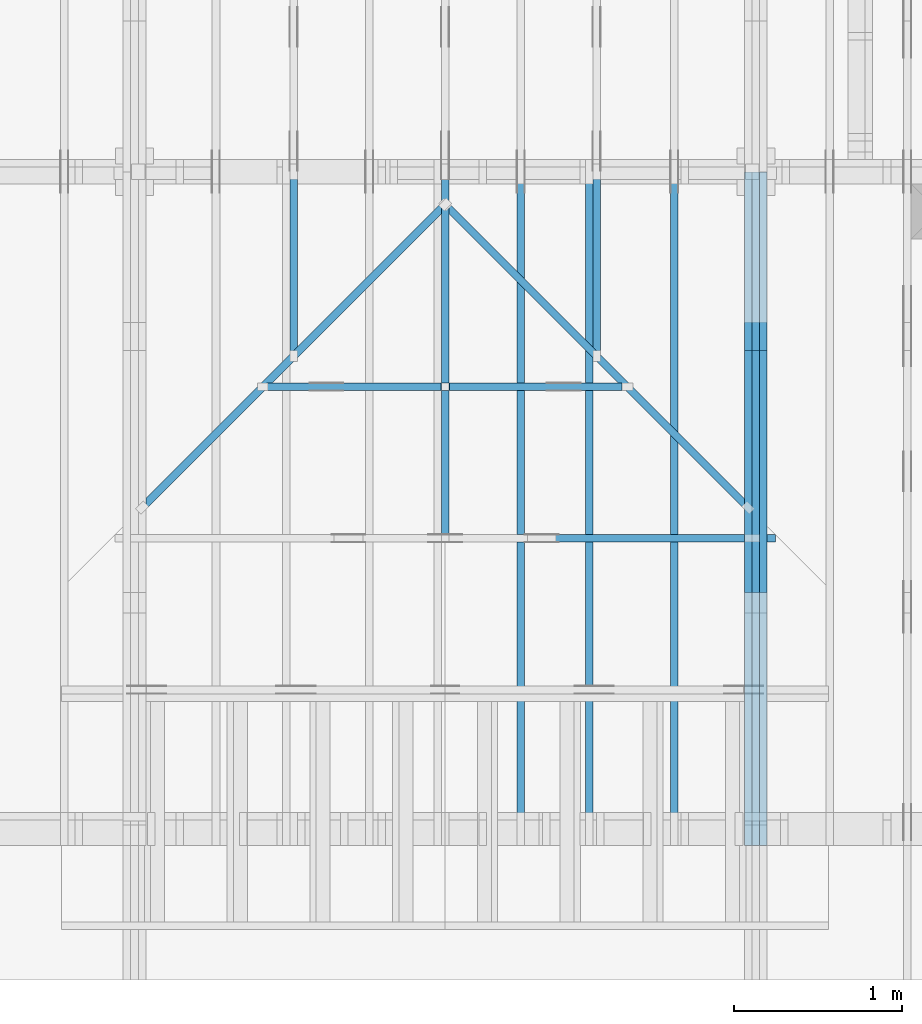
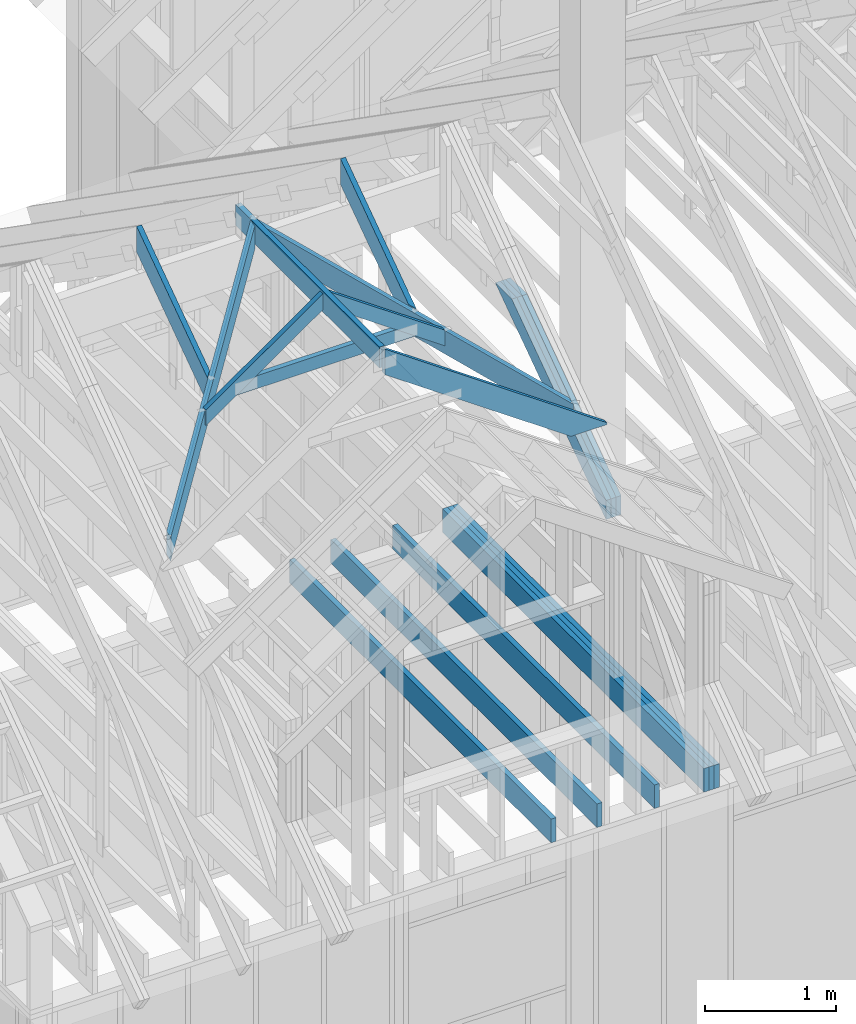
# One storey, part 9 of 70: 18 members, 11 elements without a shape of their own.
"""IFC2X3 building model written with IfcOpenShell, lengths in millimetres."""

from ifc_helpers import new_model, si_unit, frame, origin, origin_with_axes, origin_2d, place, context, project, spatial, faceted_brep, element, aggregate, save


model = new_model("IFC2X3")

# Units and contexts
model_context = context("Model", 3, precision=1e-05, world=origin())
plan_context = context("Plan", 2, precision=1e-05, world=origin_2d())
ifc_project = project(units=[si_unit("LENGTHUNIT", "METRE", prefix="MILLI"), si_unit("AREAUNIT", "SQUARE_METRE"), si_unit("VOLUMEUNIT", "CUBIC_METRE"), si_unit("SOLIDANGLEUNIT", "STERADIAN"), si_unit("PLANEANGLEUNIT", "RADIAN"), si_unit("MASSUNIT", "GRAM"), si_unit("TIMEUNIT", "SECOND"), si_unit("THERMODYNAMICTEMPERATUREUNIT", "DEGREE_CELSIUS"), si_unit("LUMINOUSINTENSITYUNIT", "LUMEN")], contexts=[model_context, plan_context])

# Site, building, storey
site_placement = place(None, origin_with_axes())
site = spatial("IfcSite", under=ifc_project, at=site_placement, CompositionType="ELEMENT")
building_placement = place(site_placement, origin_with_axes())
building = spatial("IfcBuilding", under=site, at=building_placement, Name="Layout 1", CompositionType="ELEMENT")
storey_placement = place(building_placement, origin_with_axes())
storey = spatial("IfcBuildingStorey", under=building, at=storey_placement, Name="Storey 1", CompositionType="ELEMENT", Elevation=0.0)

# Assembly, members
assembly_1_placement = place(storey_placement, frame((5660.000000000293, 8000.0, 9.122500660690286e-13), z_axis=(-1.0, 1.836909530733566e-16, 6.123031769111886e-17), x_axis=(-1.836909530733566e-16, -1.0, 0.0)))
assembly_1 = element("IfcElementAssembly", 1, at=assembly_1_placement, inside=storey, Name="T11", AssemblyPlace="FACTORY", PredefinedType="TRUSS")
member_1_placement = place(assembly_1_placement, frame((7999.999999999999, 220.0, -90.0), z_axis=(0.0, 0.0, 1.0), x_axis=(-1.0, 1.2246063538223773e-16, 0.0)))
member_1 = element("IfcMember", 2, at=member_1_placement, Name="B3", context=model_context, shape_type="Brep", body=[
    faceted_brep([(3999.9999999999995, 220.00000000000054, 45.0), (0.0, 220.00000000000054, 45.0), (0.0, 0.0, 45.0), (3999.9999999999995, 0.0, 45.0), (0.0, 220.00000000000054, 0.0), (3999.9999999999995, 220.00000000000054, 4.898425415289508e-13), (3999.9999999999995, 0.0, 4.898425415289508e-13), (0.0, 0.0, 0.0), (0.0, 0.0, 0.0), (2.755364296100349e-15, -3.3742366240998092e-31, 45.0), (2.969670408019265e-14, 220.0, 45.0), (2.69413397840923e-14, 220.0, -1.6496267940043512e-30), (3999.9999999999995, -7.347638122934263e-13, 7.805495731188194e-29), (3999.9999999999995, -7.320084479973259e-13, 45.0), (5.061354936149714e-31, 2.755364296100349e-15, 45.0), (0.0, 0.0, 0.0), (3999.9999999999995, 220.00000000000054, 0.0), (3999.9999999999995, 220.00000000000054, 45.0), (3999.9999999999995, 5.400124791776761e-13, 45.0), (3999.9999999999995, 5.400124791776761e-13, 0.0), (0.0, 220.0, 0.0), (0.0, 220.0, 45.0), (3999.9999999999995, 220.00000000000065, 45.0), (3999.9999999999995, 220.00000000000065, 6.310887241768095e-30)], [[[0, 1, 2, 3]], [[4, 5, 6, 7]], [[8, 9, 10, 11]], [[12, 13, 14, 15]], [[16, 17, 18, 19]], [[20, 21, 22, 23]]]),
])
member_2_placement = place(assembly_1_placement, frame((7999.999999999999, 220.0, -135.0), z_axis=(0.0, 0.0, 1.0), x_axis=(-1.0, 1.2246063538223773e-16, 0.0)))
member_2 = element("IfcMember", 3, at=member_2_placement, Name="B3", context=model_context, shape_type="Brep", body=[
    faceted_brep([(3999.9999999999995, 220.00000000000054, 45.0), (0.0, 220.00000000000054, 45.0), (0.0, 0.0, 45.0), (3999.9999999999995, 0.0, 45.0), (0.0, 220.00000000000054, 0.0), (3999.9999999999995, 220.00000000000054, 4.898425415289508e-13), (3999.9999999999995, 0.0, 4.898425415289508e-13), (0.0, 0.0, 0.0), (0.0, 0.0, 0.0), (2.755364296100349e-15, -3.3742366240998092e-31, 45.0), (2.969670408019265e-14, 220.0, 45.0), (2.69413397840923e-14, 220.0, -1.6496267940043512e-30), (3999.9999999999995, -7.347638122934263e-13, 7.805495731188194e-29), (3999.9999999999995, -7.320084479973259e-13, 45.0), (5.061354936149714e-31, 2.755364296100349e-15, 45.0), (0.0, 0.0, 0.0), (3999.9999999999995, 220.00000000000054, 0.0), (3999.9999999999995, 220.00000000000054, 45.0), (3999.9999999999995, 5.400124791776761e-13, 45.0), (3999.9999999999995, 5.400124791776761e-13, 0.0), (0.0, 220.0, 0.0), (0.0, 220.0, 45.0), (3999.9999999999995, 220.00000000000065, 45.0), (3999.9999999999995, 220.00000000000065, 6.310887241768095e-30)], [[[0, 1, 2, 3]], [[4, 5, 6, 7]], [[8, 9, 10, 11]], [[12, 13, 14, 15]], [[16, 17, 18, 19]], [[20, 21, 22, 23]]]),
])
member_3_placement = place(assembly_1_placement, frame((7999.999999999999, 220.0, -180.0), z_axis=(0.0, 0.0, 1.0), x_axis=(-1.0, 1.2246063538223773e-16, 0.0)))
member_3 = element("IfcMember", 4, at=member_3_placement, Name="B3", context=model_context, shape_type="Brep", body=[
    faceted_brep([(3999.9999999999995, 220.00000000000054, 45.0), (0.0, 220.00000000000054, 45.0), (0.0, 0.0, 45.0), (3999.9999999999995, 0.0, 45.0), (0.0, 220.00000000000054, 0.0), (3999.9999999999995, 220.00000000000054, 4.898425415289508e-13), (3999.9999999999995, 0.0, 4.898425415289508e-13), (0.0, 0.0, 0.0), (0.0, 0.0, 0.0), (2.755364296100349e-15, -3.3742366240998092e-31, 45.0), (2.969670408019265e-14, 220.0, 45.0), (2.69413397840923e-14, 220.0, -1.6496267940043512e-30), (3999.9999999999995, -7.347638122934263e-13, 7.805495731188194e-29), (3999.9999999999995, -7.320084479973259e-13, 45.0), (5.061354936149714e-31, 2.755364296100349e-15, 45.0), (0.0, 0.0, 0.0), (3999.9999999999995, 220.00000000000054, 0.0), (3999.9999999999995, 220.00000000000054, 45.0), (3999.9999999999995, 5.400124791776761e-13, 45.0), (3999.9999999999995, 5.400124791776761e-13, 0.0), (0.0, 220.0, 0.0), (0.0, 220.0, 45.0), (3999.9999999999995, 220.00000000000065, 45.0), (3999.9999999999995, 220.00000000000065, 6.310887241768095e-30)], [[[0, 1, 2, 3]], [[4, 5, 6, 7]], [[8, 9, 10, 11]], [[12, 13, 14, 15]], [[16, 17, 18, 19]], [[20, 21, 22, 23]]]),
])
member_4_placement = place(assembly_1_placement, frame((6583.168583266467, 1754.0249935609681, -90.0), z_axis=(0.0, 0.0, 1.0), x_axis=(-0.8191520442887741, 0.573576436351357, 0.0)))
member_4 = element("IfcMember", 5, at=member_4_placement, Name="SC5", context=model_context, shape_type="Brep", body=[
    faceted_brep([(2065.5521701629054, 145.00000000003, 45.0), (0.0, 145.00000000003, 45.0), (101.53009304118586, 0.0, 45.0), (1858.4707091852106, 0.0, 45.0), (0.0, 145.00000000003, 0.0), (2065.5521701629054, 145.00000000003, 2.529488311733094e-13), (1858.4707091852106, 0.0, 2.275895038860988e-13), (101.53009304118586, 0.0, 1.2433439704241334e-14), (101.53009304118586, 0.0, 4.2995835069684415e-31), (101.53009304118586, 0.0, 45.0), (2.842170943040401e-14, 145.0000000000155, 45.0), (2.842170943040401e-14, 145.0000000000155, -2.4234235555743734e-30), (1858.4707091852106, 2.77410857254784e-11, 2.7752643298715197e-29), (1858.4707091852106, 2.77438410897745e-11, 45.0), (101.53009304118586, -2.2006133120472472e-14, 45.0), (101.53009304118586, -2.476149741657282e-14, 1.5161543533245607e-30), (2065.5521701629054, 145.0000000000299, 1.0940328964451725e-29), (2065.5521701629054, 145.0000000000299, 45.0), (1858.4707091852106, 2.808064891723916e-11, 45.0), (1858.4707091852106, 2.808064891723916e-11, 9.382329999429724e-30), (0.0, 145.00000000001546, 0.0), (0.0, 145.00000000001546, 45.0), (2065.5521701629054, 145.00000000003047, 45.0), (2065.5521701629054, 145.00000000003047, 2.68212707775144e-29)], [[[0, 1, 2, 3]], [[4, 5, 6, 7]], [[8, 9, 10, 11]], [[12, 13, 14, 15]], [[16, 17, 18, 19]], [[20, 21, 22, 23]]]),
])
member_5_placement = place(assembly_1_placement, frame((6583.168583266467, 1754.0249935609681, -135.0), z_axis=(0.0, 0.0, 1.0), x_axis=(-0.8191520442887741, 0.573576436351357, 0.0)))
member_5 = element("IfcMember", 6, at=member_5_placement, Name="SC5", context=model_context, shape_type="Brep", body=[
    faceted_brep([(2065.5521701629054, 145.00000000003, 45.0), (0.0, 145.00000000003, 45.0), (101.53009304118586, 0.0, 45.0), (1858.4707091852106, 0.0, 45.0), (0.0, 145.00000000003, 0.0), (2065.5521701629054, 145.00000000003, 2.529488311733094e-13), (1858.4707091852106, 0.0, 2.275895038860988e-13), (101.53009304118586, 0.0, 1.2433439704241334e-14), (101.53009304118586, 0.0, 4.2995835069684415e-31), (101.53009304118586, 0.0, 45.0), (2.842170943040401e-14, 145.0000000000155, 45.0), (2.842170943040401e-14, 145.0000000000155, -2.4234235555743734e-30), (1858.4707091852106, 2.77410857254784e-11, 2.7752643298715197e-29), (1858.4707091852106, 2.77438410897745e-11, 45.0), (101.53009304118586, -2.2006133120472472e-14, 45.0), (101.53009304118586, -2.476149741657282e-14, 1.5161543533245607e-30), (2065.5521701629054, 145.0000000000299, 1.0940328964451725e-29), (2065.5521701629054, 145.0000000000299, 45.0), (1858.4707091852106, 2.808064891723916e-11, 45.0), (1858.4707091852106, 2.808064891723916e-11, 9.382329999429724e-30), (0.0, 145.00000000001546, 0.0), (0.0, 145.00000000001546, 45.0), (2065.5521701629054, 145.00000000003047, 45.0), (2065.5521701629054, 145.00000000003047, 2.68212707775144e-29)], [[[0, 1, 2, 3]], [[4, 5, 6, 7]], [[8, 9, 10, 11]], [[12, 13, 14, 15]], [[16, 17, 18, 19]], [[20, 21, 22, 23]]]),
])
member_6_placement = place(assembly_1_placement, frame((6583.168583266467, 1754.0249935609681, -180.0), z_axis=(0.0, 0.0, 1.0), x_axis=(-0.8191520442887741, 0.573576436351357, 0.0)))
member_6 = element("IfcMember", 7, at=member_6_placement, Name="SC5", context=model_context, shape_type="Brep", body=[
    faceted_brep([(2065.5521701629054, 145.00000000003, 45.0), (0.0, 145.00000000003, 45.0), (101.53009304118586, 0.0, 45.0), (1858.4707091852106, 0.0, 45.0), (0.0, 145.00000000003, 0.0), (2065.5521701629054, 145.00000000003, 2.529488311733094e-13), (1858.4707091852106, 0.0, 2.275895038860988e-13), (101.53009304118586, 0.0, 1.2433439704241334e-14), (101.53009304118586, 0.0, 4.2995835069684415e-31), (101.53009304118586, 0.0, 45.0), (2.842170943040401e-14, 145.0000000000155, 45.0), (2.842170943040401e-14, 145.0000000000155, -2.4234235555743734e-30), (1858.4707091852106, 2.77410857254784e-11, 2.7752643298715197e-29), (1858.4707091852106, 2.77438410897745e-11, 45.0), (101.53009304118586, -2.2006133120472472e-14, 45.0), (101.53009304118586, -2.476149741657282e-14, 1.5161543533245607e-30), (2065.5521701629054, 145.0000000000299, 1.0940328964451725e-29), (2065.5521701629054, 145.0000000000299, 45.0), (1858.4707091852106, 2.808064891723916e-11, 45.0), (1858.4707091852106, 2.808064891723916e-11, 9.382329999429724e-30), (0.0, 145.00000000001546, 0.0), (0.0, 145.00000000001546, 45.0), (2065.5521701629054, 145.00000000003047, 45.0), (2065.5521701629054, 145.00000000003047, 2.68212707775144e-29)], [[[0, 1, 2, 3]], [[4, 5, 6, 7]], [[8, 9, 10, 11]], [[12, 13, 14, 15]], [[16, 17, 18, 19]], [[20, 21, 22, 23]]]),
])
aggregate(assembly_1, [member_1, member_2, member_3, member_4, member_5, member_6])

# Assembly, member
assembly_2_placement = place(storey_placement, frame((4355.0, 8000.0, 1.3776821480501744e-15), z_axis=(-1.0, 1.836909530733566e-16, 6.123031769111886e-17), x_axis=(-1.836909530733566e-16, -1.0, 0.0)))
assembly_2 = element("IfcElementAssembly", 8, at=assembly_2_placement, inside=storey, Name="MB1", AssemblyPlace="FACTORY", PredefinedType="TRUSS")
member_7_placement = place(assembly_2_placement, frame((8000.000000000001, 220.0, -45.0), z_axis=(0.0, 0.0, 1.0), x_axis=(-1.0, 1.2246063538223773e-16, 0.0)))
member_7 = element("IfcMember", 9, at=member_7_placement, Name="B3", context=model_context, shape_type="Brep", body=[
    faceted_brep([(4000.0000000000005, 220.0000000000005, 45.0), (0.0, 220.0000000000005, 45.0), (0.0, 0.0, 45.0), (4000.0000000000005, 0.0, 45.0), (0.0, 220.0000000000005, 0.0), (4000.0000000000005, 220.0000000000005, 4.89842541528951e-13), (4000.0000000000005, 0.0, 4.89842541528951e-13), (0.0, 0.0, 0.0), (0.0, 0.0, 0.0), (2.755364296100349e-15, -3.3742366240998092e-31, 45.0), (2.969670408019265e-14, 220.0, 45.0), (2.69413397840923e-14, 220.0, -1.6496267940043512e-30), (4000.0000000000005, -7.347638122934265e-13, 7.631468701413364e-29), (4000.0000000000005, -7.320084479973261e-13, 45.0), (5.061354936149714e-31, 2.755364296100349e-15, 45.0), (0.0, 0.0, 0.0), (4000.0000000000005, 220.0000000000005, 0.0), (4000.0000000000005, 220.0000000000005, 45.0), (4000.0000000000005, 5.115907697472721e-13, 45.0), (4000.0000000000005, 5.115907697472721e-13, 0.0), (0.0, 220.0, 0.0), (0.0, 220.0, 45.0), (4000.0000000000005, 220.00000000000065, 45.0), (4000.0000000000005, 220.00000000000065, 7.888609052210118e-30)], [[[0, 1, 2, 3]], [[4, 5, 6, 7]], [[8, 9, 10, 11]], [[12, 13, 14, 15]], [[16, 17, 18, 19]], [[20, 21, 22, 23]]]),
])
aggregate(assembly_2, [member_7])

assembly_3_placement = place(storey_placement, frame((5266.250000000146, 8000.0, 1.3776821480501744e-15), z_axis=(-1.0, 1.836909530733566e-16, 6.123031769111886e-17), x_axis=(-1.836909530733566e-16, -1.0, 0.0)))
assembly_3 = element("IfcElementAssembly", 10, at=assembly_3_placement, inside=storey, Name="MB1", AssemblyPlace="FACTORY", PredefinedType="TRUSS")
member_8_placement = place(assembly_3_placement, frame((8000.000000000001, 220.0, -45.0), z_axis=(0.0, 0.0, 1.0), x_axis=(-1.0, 1.2246063538223773e-16, 0.0)))
member_8 = element("IfcMember", 11, at=member_8_placement, Name="B3", context=model_context, shape_type="Brep", body=[
    faceted_brep([(4000.0000000000005, 220.0000000000005, 45.0), (0.0, 220.0000000000005, 45.0), (0.0, 0.0, 45.0), (4000.0000000000005, 0.0, 45.0), (0.0, 220.0000000000005, 0.0), (4000.0000000000005, 220.0000000000005, 4.89842541528951e-13), (4000.0000000000005, 0.0, 4.89842541528951e-13), (0.0, 0.0, 0.0), (0.0, 0.0, 0.0), (2.755364296100349e-15, -3.3742366240998092e-31, 45.0), (2.969670408019265e-14, 220.0, 45.0), (2.69413397840923e-14, 220.0, -1.6496267940043512e-30), (4000.0000000000005, -7.347638122934265e-13, 7.631468701413364e-29), (4000.0000000000005, -7.320084479973261e-13, 45.0), (5.061354936149714e-31, 2.755364296100349e-15, 45.0), (0.0, 0.0, 0.0), (4000.0000000000005, 220.0000000000005, 0.0), (4000.0000000000005, 220.0000000000005, 45.0), (4000.0000000000005, 5.115907697472721e-13, 45.0), (4000.0000000000005, 5.115907697472721e-13, 0.0), (0.0, 220.0, 0.0), (0.0, 220.0, 45.0), (4000.0000000000005, 220.00000000000065, 45.0), (4000.0000000000005, 220.00000000000065, 7.888609052210118e-30)], [[[0, 1, 2, 3]], [[4, 5, 6, 7]], [[8, 9, 10, 11]], [[12, 13, 14, 15]], [[16, 17, 18, 19]], [[20, 21, 22, 23]]]),
])
aggregate(assembly_3, [member_8])

assembly_4_placement = place(storey_placement, frame((5910.470169573801, 1845.0, 1.3776821480501744e-15), z_axis=(1.2246063538223773e-16, 1.0, 6.123031769111886e-17), x_axis=(-1.0, 1.2246063538223773e-16, 0.0)))
assembly_4 = element("IfcElementAssembly", 12, at=assembly_4_placement, inside=storey, Name="T6", AssemblyPlace="FACTORY", PredefinedType="TRUSS")
member_9_placement = place(assembly_4_placement, frame((126.94513170141886, 2126.9651317341068, -45.0), z_axis=(0.0, 0.0, 1.0), x_axis=(0.8191520442889915, 0.5735764363510465, 0.0)))
member_9 = element("IfcMember", 13, at=member_9_placement, Name="T15", context=model_context, shape_type="Brep", body=[
    faceted_brep([(2402.328672292534, 195.0000000028765, 45.0), (9.036507251027615, 195.0000000028765, 45.0), (0.0, 182.09453018306226, 45.0), (260.05794032032895, 0.0, 45.0), (2265.788202340448, 0.0, 45.0), (9.036507251027615, 195.0000000028765, 1.10661641959704e-15), (2402.328672292534, 195.0000000028765, 2.9419069560591125e-13), (2265.788202340448, 0.0, 2.774698629001895e-13), (260.05794032032895, 0.0, 3.1846860607823545e-14), (0.0, 182.09453018306226, 0.0), (0.0, 182.09453018306226, 1.70814952506554e-30), (0.0, 182.09453018306226, 45.0), (9.03650725102763, 195.00000000152798, 45.0), (9.03650725102763, 195.00000000152798, 1.8052451729587168e-30), (260.0579403203289, -4.263256414560601e-14, 4.733165431326071e-30), (260.0579403203289, -4.263256414560601e-14, 45.0), (4.263256414560601e-14, 182.09453018306232, 45.0), (4.263256414560601e-14, 182.09453018306232, -4.733165431326071e-30), (2265.788202340448, 1.1716974645044216e-09, 6.710557680191079e-29), (2265.788202340448, 1.1717002198687177e-09, 45.0), (260.05794032032895, -1.2303370630569984e-13, 45.0), (260.05794032032895, -1.257890706018002e-13, 7.702104755019455e-30), (2402.3286722925336, 195.0000000028772, -3.7865323450608567e-29), (2402.3286722925336, 195.0000000028772, 45.0), (2265.7882023404477, 1.1732481652870774e-09, 45.0), (2265.7882023404477, 1.1732481652870774e-09, -3.7865323450608567e-29), (9.036507251027615, 195.00000000152795, 0.0), (9.036507251027615, 195.00000000152795, 45.0), (2402.328672292534, 195.00000000287653, 45.0), (2402.328672292534, 195.00000000287653, 3.1554436208840472e-30)], [[[0, 1, 2, 3, 4]], [[5, 6, 7, 8, 9]], [[10, 11, 12, 13]], [[14, 15, 16, 17]], [[18, 19, 20, 21]], [[22, 23, 24, 25]], [[26, 27, 28, 29]]]),
])
aggregate(assembly_4, [member_9])

# Assembly, members
assembly_5_placement = place(storey_placement, frame((5010.470169573802, 2745.0, 1.3776821480501744e-15), z_axis=(1.2246063538223773e-16, 1.0, 6.123031769111886e-17), x_axis=(-1.0, 1.2246063538223773e-16, 0.0)))
assembly_5 = element("IfcElementAssembly", 14, at=assembly_5_placement, inside=storey, Name="T5", AssemblyPlace="FACTORY", PredefinedType="TRUSS")
member_10_placement = place(assembly_5_placement, frame((31.8198051533941, 2782.102539556101, -45.0), z_axis=(0.0, 0.0, 1.0), x_axis=(0.8191520442889916, 0.5735764363510464, 0.0)))
member_10 = element("IfcMember", 15, at=member_10_placement, Name="T23", context=model_context, shape_type="Brep", body=[
    faceted_brep([(1336.1128064243578, 120.00000000153977, 45.0), (84.02490458540615, 120.00000000153977, 45.0), (0.0, 2.684828359633684e-09, 45.0), (1252.0879018399944, 2.684828359633684e-09, 45.0), (84.02490458540615, 120.00000000034379, 1.0289743203460738e-14), (1336.1128064243578, 120.00000000034379, 1.6362122321707165e-13), (1252.0879018399944, 2.684828359633684e-09, 1.5333148001373862e-13), (0.0, 2.684828359633684e-09, 0.0), (84.02490458540615, 120.00000000034379, 0.0), (84.02490458540615, 120.00000000034377, 45.0), (1336.1128064243578, 120.00000000153975, 45.0), (1336.1128064243578, 120.00000000153975, -3.1554436208840472e-30), (1.164085069105157e-14, -8.151011405048039e-15, -8.701351488741532e-31), (1.3897912986963067e-14, -9.731423438854188e-15, 45.0), (84.02490458540613, 120.00000000034379, 45.0), (84.02490458540613, 120.00000000034379, 2.399280079755067e-30), (1252.0879018399944, 2.684324976692266e-09, 3.08222974233199e-29), (1252.0879018399944, 2.684327732056562e-09, 45.0), (-5.9071676908938386e-27, 2.755364296100349e-15, 45.0), (0.0, 0.0, 0.0), (1336.1128064243585, 120.00000000153955, 3.7865323450608567e-29), (1336.1128064243585, 120.00000000153955, 45.0), (1252.0879018399949, 2.6844872991205193e-09, 45.0), (1252.0879018399949, 2.6844872991205193e-09, 3.7865323450608567e-29)], [[[0, 1, 2, 3]], [[4, 5, 6, 7]], [[8, 9, 10, 11]], [[12, 13, 14, 15]], [[16, 17, 18, 19]], [[20, 21, 22, 23]]]),
])
member_11_placement = place(assembly_5_placement, frame((1039.6409972112772, 3548.465361629326, -45.00000000000001), z_axis=(0.0, 0.0, 1.0), x_axis=(0.8191520442889916, -0.5735764363510465, 0.0)))
member_11 = element("IfcMember", 16, at=member_11_placement, Name="T22", context=model_context, shape_type="Brep", body=[
    faceted_brep([(1263.465283141054, 120.00000000181171, 45.0), (0.0, 120.00000000181171, 45.0), (84.02490458540615, 0.0, 45.0), (1347.49018772646, 0.0, 45.0), (0.0, 120.00000000181171, 0.0), (1263.465283141054, 120.00000000181171, 1.5472476135685237e-13), (1347.49018772646, 0.0, 1.6501450456031308e-13), (84.02490458540615, 0.0, 1.0289743203460738e-14), (84.02490458540615, -2.1316282072803006e-14, 7.888609052210116e-31), (84.02490458540615, -2.1316282072803006e-14, 45.0), (4.263256414560601e-14, 120.00000000034382, 45.0), (4.263256414560601e-14, 120.00000000034382, -3.1554436208840472e-30), (1347.49018772646, 1.4675600276772321e-09, 2.2313612640413609e-29), (1347.49018772646, 1.4675627830415282e-09, 45.0), (84.02490458540615, -1.9968688696242525e-14, 45.0), (84.02490458540615, -2.2724052992342873e-14, 1.3914009839511772e-30), (1263.4652831410542, 120.00000000181171, 1.262177448353619e-29), (1263.4652831410542, 120.00000000181171, 45.0), (1347.4901877264601, 1.4680381354992278e-09, 45.0), (1347.4901877264601, 1.4680381354992278e-09, 0.0), (0.0, 120.00000000034379, 0.0), (0.0, 120.00000000034379, 45.0), (1263.465283141054, 120.0000000018118, 45.0), (1263.465283141054, 120.00000000181181, 6.310887241768095e-30)], [[[0, 1, 2, 3]], [[4, 5, 6, 7]], [[8, 9, 10, 11]], [[12, 13, 14, 15]], [[16, 17, 18, 19]], [[20, 21, 22, 23]]]),
])
member_12_placement = place(assembly_5_placement, frame((1872.915890428325, 3084.9999999987845, -45.0), z_axis=(0.0, 0.0, 1.0), x_axis=(-1.0, 1.2246063538223773e-16, 0.0)))
member_12 = element("IfcMember", 17, at=member_12_placement, Name="C2", context=model_context, shape_type="Brep", body=[
    faceted_brep([(1579.891441709231, 120.00000000000728, 45.0), (0.0, 120.00000000000728, 45.0), (171.377760809366, 0.0, 45.0), (1408.513680900418, 0.0, 45.0), (0.0, 120.00000000000728, 0.0), (1579.891441709231, 120.00000000000728, 1.9347450978667203e-13), (1408.513680900418, 0.0, 1.7248748030763963e-13), (171.377760809366, 0.0, 2.098702947910012e-14), (171.377760809366, -1.4210854715202004e-14, 1.6540468339152815e-30), (171.377760809366, -1.4210854715202004e-14, 45.0), (7.105427357601002e-15, 120.00000000000682, 45.0), (7.105427357601002e-15, 120.00000000000682, -1.2130534303392788e-30), (1408.513680900418, 7.490426309123959e-12, -1.3131986326008574e-29), (1408.513680900418, 7.49318167342006e-12, 45.0), (171.377760809366, 2.8850364437752607e-14, 45.0), (171.377760809366, 2.6095000141652258e-14, -1.597805148823167e-30), (1579.8914417092312, 120.00000000000728, 6.310887241768095e-30), (1579.8914417092312, 120.00000000000728, 45.0), (1408.513680900418, 7.16227077646181e-12, 45.0), (1408.513680900418, 7.16227077646181e-12, 6.310887241768095e-30), (0.0, 120.00000000000682, 0.0), (0.0, 120.00000000000682, 45.0), (1579.891441709231, 120.00000000000742, 45.0), (1579.891441709231, 120.00000000000743, 9.466330862652142e-30)], [[[0, 1, 2, 3]], [[4, 5, 6, 7]], [[8, 9, 10, 11]], [[12, 13, 14, 15]], [[16, 17, 18, 19]], [[20, 21, 22, 23]]]),
])
aggregate(assembly_5, [member_10, member_11, member_12])

# Assembly, member
assembly_6_placement = place(storey_placement, frame((3950.0000000003492, 1845.0000000000036, 2291.882907996914), z_axis=(1.0, 1.6780449100563255e-13, 6.123031769111886e-17), x_axis=(-1.6780449100563255e-13, 1.0, 0.0)))
assembly_6 = element("IfcElementAssembly", 18, at=assembly_6_placement, inside=storey, AssemblyPlace="FACTORY", PredefinedType="TRUSS")
member_13_placement = place(assembly_6_placement, frame((-3.673798542941224e-12, 1177.7359911706299, -45.0), z_axis=(0.0, 0.0, 1.0), x_axis=(1.0, 0.0, 0.0)))
member_13 = element("IfcMember", 19, at=member_13_placement, Name="T16", context=model_context, shape_type="Brep", body=[
    faceted_brep([(2200.0000000000036, 195.0, 45.0), (3.581973584951133e-14, 195.0, 45.0), (0.0, 0.0, 45.0), (2200.0000000000036, 0.0, 45.0), (3.581973584951133e-14, 195.0, 4.386507611355076e-30), (2200.0000000000036, 195.0, 2.6941339784092345e-13), (2200.0000000000036, 0.0, 2.6941339784092345e-13), (0.0, 0.0, 0.0), (0.0, 0.0, 0.0), (2.755364296100349e-15, -3.3742366240998092e-31, 45.0), (2.6635188195636705e-14, 195.0, 45.0), (2.3879823899536357e-14, 195.0, 7.310846019009541e-31), (2200.0000000000036, -4.0412009676138515e-13, 2.474440191006531e-29), (2200.0000000000036, -4.013647324652848e-13, 45.0), (5.061354936149714e-31, 2.755364296100349e-15, 45.0), (0.0, 0.0, 0.0), (2200.0000000000036, 195.0, 0.0), (2200.0000000000036, 195.0, 45.0), (2200.0000000000036, 0.0, 45.0), (2200.0000000000036, 0.0, 0.0), (3.581973584951133e-14, 195.0, 0.0), (3.581973584951133e-14, 195.0, 45.0), (2200.0000000000036, 194.99999999999986, 45.0), (2200.0000000000036, 194.99999999999986, -7.888609052210118e-30)], [[[0, 1, 2, 3]], [[4, 5, 6, 7]], [[8, 9, 10, 11]], [[12, 13, 14, 15]], [[16, 17, 18, 19]], [[20, 21, 22, 23]]]),
])
aggregate(assembly_6, [member_13])

assembly_7_placement = place(storey_placement, frame((2165.909902576696, 2012.0602669971047, 2200.0), z_axis=(0.7071067811865475, -0.7071067811865476, 6.123031769111886e-17), x_axis=(0.7071067811865476, 0.7071067811865475, 0.0)))
assembly_7 = element("IfcElementAssembly", 20, at=assembly_7_placement, inside=storey, AssemblyPlace="FACTORY", PredefinedType="TRUSS")
member_14_placement = place(assembly_7_placement, frame((-22.49999999968288, -8.73308738571861, -45.00000000000001), z_axis=(0.0, 0.0, 1.0), x_axis=(0.8961691375117274, 0.44371260627965775, 0.0)))
member_14 = element("IfcMember", 21, at=member_14_placement, Name="T13", context=model_context, shape_type="Brep", body=[
    faceted_brep([(2916.2673102603267, 195.00000000132388, 2.7966962079517543e-11), (2866.053574798573, 195.0000000013407, 45.000000000018645), (2769.5048825892227, 1.6370904631912708e-11, 45.00000000000023), (2819.7186180509757, -5.684341886080801e-13, 9.777068044058979e-12), (96.54869220933452, 195.00000000134935, 45.0), (2866.0535747985564, 195.00000000134918, 45.0), (2916.267310260302, 195.00000000134918, 7.105427357600997e-15), (146.76242767106436, 195.00000000134935, 7.105427357600994e-15), (5.293543381412746e-13, 7.197797913249815e-10, 45.00000000000006), (96.54869220933492, 195.00000000205225, 44.999999999999986), (146.7624276710646, 195.00000000203974, -1.7763568394002505e-14), (50.213735461730195, 7.071037089190213e-10, -1.7763568394002505e-14), (2819.7186180509675, 3.723071594493595e-12, 7.105427357602832e-15), (2769.504882589222, 3.9548749265898174e-12, 45.00000000000001), (3.5882408155885064e-13, 4.463607918013946e-12, 45.00000000000001), (50.21373546173021, 4.231804585917726e-12, 7.105427357601035e-15), (146.76242767106461, 195.0000000020397, 2.5078047500439282e-14), (2916.267310260302, 195.0000000020397, 3.64233375116527e-13), (2819.718618050967, 3.865352482534945e-12, 3.5240996092324773e-13), (50.21373546173021, 3.865352482534945e-12, 1.3254633307160086e-14), (2866.0535747985564, 195.00000000134924, 45.00000000000001), (96.54869220933493, 195.00000000134924, 45.00000000000001), (0.0, 7.198170948186089e-10, 45.00000000000001), (2769.5048825892222, 7.198170948186089e-10, 45.00000000000001)], [[[0, 1, 2, 3]], [[4, 5, 6, 7]], [[8, 9, 10, 11]], [[12, 13, 14, 15]], [[16, 17, 18, 19]], [[20, 21, 22, 23]]]),
])
aggregate(assembly_7, [member_14])

assembly_8_placement = place(storey_placement, frame((5689.090097423301, 2012.060266997107, 2200.0), z_axis=(-0.7071067811865477, -0.7071067811865474, 6.123031769111886e-17), x_axis=(0.7071067811865474, -0.7071067811865477, 0.0)))
assembly_8 = element("IfcElementAssembly", 22, at=assembly_8_placement, inside=storey, AssemblyPlace="FACTORY", PredefinedType="TRUSS")
member_15_placement = place(assembly_8_placement, frame((-2590.9687601895002, 1285.2514814588394, -45.00000000001127), z_axis=(0.0, 0.0, 1.0), x_axis=(0.8961691375117272, -0.44371260627965814, 0.0)))
member_15 = element("IfcMember", 23, at=member_15_placement, Name="T13", context=model_context, shape_type="Brep", body=[
    faceted_brep([(2769.5048825903664, 194.9999999996777, 1.1368683772161603e-11), (2819.718618052122, 194.99999999966337, 45.00000000001137), (2916.2673102606304, 3.410605131648481e-13, 45.00000000001137), (2866.0535747988743, 1.4665602066088468e-11, 1.1596057447604835e-11), (2916.2673102606304, 1.3992701458862727e-11, 45.00000000001127), (146.76242767029544, 1.450143445028706e-11, 45.00000000001127), (96.54869220851924, 1.4547870923801812e-11, 1.1269207789155189e-11), (2866.0535747988743, 1.4039137932377475e-11, 1.1269207789155187e-11), (146.76242767031684, 7.91271048683484e-10, 44.999999999987736), (50.21373546178757, 195.0000000004439, 45.00000000001123), (7.105427357601002e-15, 195.00000000045273, 2.3462121134798508e-11), (96.54869220852902, 8.000355933290848e-10, -2.8421709430404007e-13), (1.0913936421275139e-11, 194.9999999996633, 1.1269207789155189e-11), (50.21373546178802, 194.99999999966326, 45.00000000001127), (2819.7186180521226, 194.9999999996631, 45.00000000001127), (2769.5048825903664, 194.99999999966312, 1.1269207789155189e-11), (2819.718618052122, 194.9999999996631, 45.00000000001127), (50.213735461787564, 194.9999999996631, 45.00000000001127), (146.76242767029544, 7.808091950778362e-10, 45.00000000001127), (2916.26731026063, 7.808091950778362e-10, 45.00000000001127), (1.0913936421275139e-11, 195.00000000045839, 1.126920778915519e-11), (2769.5048825903664, 195.00000000045839, 1.1608363116771414e-11), (2866.0535747988743, 1.440003671859813e-11, 1.1620186530964592e-11), (96.54869220851879, 1.440003671859813e-11, 1.1281031203348368e-11)], [[[0, 1, 2, 3]], [[4, 5, 6, 7]], [[8, 9, 10, 11]], [[12, 13, 14, 15]], [[16, 17, 18, 19]], [[20, 21, 22, 23]]]),
])
aggregate(assembly_8, [member_15])

assembly_9_placement = place(storey_placement, frame((4760.0, 4072.500000000002, 1.3776821480501744e-15), z_axis=(-1.0, 1.836909530733566e-16, 6.123031769111886e-17), x_axis=(-1.836909530733566e-16, -1.0, 0.0)))
assembly_9 = element("IfcElementAssembly", 24, at=assembly_9_placement, inside=storey, Name="MB2", AssemblyPlace="FACTORY", PredefinedType="TRUSS")
member_16_placement = place(assembly_9_placement, frame((4072.500000000002, 220.0, -45.0), z_axis=(0.0, 0.0, 1.0), x_axis=(-1.0, 1.2246063538223773e-16, 0.0)))
member_16 = element("IfcMember", 25, at=member_16_placement, Name="B2", context=model_context, shape_type="Brep", body=[
    faceted_brep([(4072.500000000002, 220.0000000000005, 45.0), (0.0, 220.0000000000005, 45.0), (0.0, 0.0, 45.0), (4072.500000000002, 0.0, 45.0), (0.0, 220.0000000000005, 0.0), (4072.500000000002, 220.0000000000005, 4.987209375941633e-13), (4072.500000000002, 0.0, 4.987209375941633e-13), (0.0, 0.0, 0.0), (0.0, 0.0, 0.0), (2.755364296100349e-15, -3.3742366240998092e-31, 45.0), (2.969670408019265e-14, 220.0, 45.0), (2.69413397840923e-14, 220.0, -1.6496267940043512e-30), (4072.500000000002, -7.48081406391245e-13, 7.713012753162445e-29), (4072.500000000002, -7.453260420951447e-13, 45.0), (5.061354936149714e-31, 2.755364296100349e-15, 45.0), (0.0, 0.0, 0.0), (4072.500000000002, 220.0000000000005, 0.0), (4072.500000000002, 220.0000000000005, 45.0), (4072.500000000002, 5.115907697472721e-13, 45.0), (4072.500000000002, 5.115907697472721e-13, 0.0), (0.0, 220.0, 0.0), (0.0, 220.0, 45.0), (4072.500000000002, 220.00000000000065, 45.0), (4072.500000000002, 220.00000000000065, 7.888609052210118e-30)], [[[0, 1, 2, 3]], [[4, 5, 6, 7]], [[8, 9, 10, 11]], [[12, 13, 14, 15]], [[16, 17, 18, 19]], [[20, 21, 22, 23]]]),
])
aggregate(assembly_9, [member_16])

assembly_10_placement = place(storey_placement, frame((3004.9999999999995, 3954.9999999999995, 3769.3208136194016), z_axis=(-1.0, -7.80991482422777e-15, 6.123031769111886e-17), x_axis=(7.80991482422777e-15, -1.0, 0.0)))
assembly_10 = element("IfcElementAssembly", 26, at=assembly_10_placement, inside=storey, AssemblyPlace="FACTORY", PredefinedType="TRUSS")
member_17_placement = place(assembly_10_placement, frame((-156.8474050876809, -128.2253094162896, -45.00000000000001), z_axis=(0.0, 0.0, 1.0), x_axis=(0.8191520442889916, -0.5735764363510465, 0.0)))
member_17 = element("IfcMember", 27, at=member_17_placement, Name="T17", context=model_context, shape_type="Brep", body=[
    faceted_brep([(1269.8619658275302, 194.99999999922744, 6.480149750132114e-12), (1324.7968223217886, 194.9999999992537, 45.00000000000455), (1461.3372922717417, 6.044729161658324e-10, 44.999999999999886), (1406.4024357774833, 5.783817869087216e-10, 1.9326762412674725e-12), (0.0, 194.99999999925615, 0.0), (-1.6871183120499046e-31, 194.99999999925615, 45.0), (1324.7968223217924, 194.99999999925606, 45.0), (1269.8619658275356, 194.99999999925606, -4.733165431326071e-30), (5.684341886080802e-14, 194.99999999865193, 6.961081190993225e-30), (1269.8619658275356, 194.99999999865193, 1.5550810318297747e-13), (1406.402435777485, 5.793481250293553e-10, 1.722289358884376e-13), (136.54046994994957, 5.793481250293553e-10, 1.6720832705460163e-14), (136.54046994994962, -2.842170943040401e-14, 1.5777218104420236e-29), (136.54046994994962, -1.4210854715202004e-14, 45.0), (2.1316282072803006e-13, 194.99999999865176, 45.0), (1.9895196601282805e-13, 194.99999999865176, -9.466330862652142e-30), (1461.337292271742, 5.790194905105651e-10, 45.0), (136.54046994994957, 5.79262843701486e-10, 45.0), (136.54046994994957, 5.792600883371899e-10, 1.9099740342692437e-30), (1406.402435777485, 5.790268261824154e-10, 1.967323047192214e-29), (1324.7968223217924, 194.99999999925615, 45.0), (1.2079226507921703e-13, 194.99999999925615, 45.0), (136.5404699499494, 0.0, 45.0), (1461.337292271742, 0.0, 45.0)], [[[0, 1, 2, 3]], [[4, 5, 6, 7]], [[8, 9, 10, 11]], [[12, 13, 14, 15]], [[16, 17, 18, 19]], [[20, 21, 22, 23]]]),
])
aggregate(assembly_10, [member_17])

assembly_11_placement = place(storey_placement, frame((4804.999999999999, 3955.000000000001, 3769.320813619403), z_axis=(-1.0, -7.044874666267686e-16, 6.123031769111886e-17), x_axis=(7.044874666267686e-16, -1.0, 0.0)))
assembly_11 = element("IfcElementAssembly", 28, at=assembly_11_placement, inside=storey, AssemblyPlace="FACTORY", PredefinedType="TRUSS")
member_18_placement = place(assembly_11_placement, frame((-156.84740508768095, -128.22530941628955, -45.00000000000051), z_axis=(0.0, 0.0, 1.0), x_axis=(0.8191520442889916, -0.5735764363510465, 0.0)))
member_18 = element("IfcMember", 29, at=member_18_placement, Name="T17", context=model_context, shape_type="Brep", body=[
    faceted_brep([(1269.861965827545, 194.99999999923068, 44.99999999999966), (1406.4024357774952, 5.793481250293553e-10, 45.00000000000068), (1461.3372922717424, 6.047571332601365e-10, 9.094947017729282e-13), (1324.7968223217922, 194.99999999925598, 1.1368683772161603e-13), (5.684341886080802e-14, 194.99999999923105, 5.115907697472723e-13), (5.684341886080802e-14, 194.99999999923116, 45.000000000000504), (1269.8619658275456, 194.99999999923108, 45.000000000000504), (1324.7968223217927, 194.99999999923097, 5.115907697472723e-13), (136.54046994994968, -1.4210854715202004e-14, 5.115907697472721e-13), (136.54046994994968, 0.0, 45.00000000000051), (2.984279490192421e-13, 194.9999999986518, 45.00000000000051), (2.8421709430404007e-13, 194.9999999986518, 5.115907697472721e-13), (1461.337292271742, 6.041848478852425e-10, 5.115907697472725e-13), (1406.4024357774952, 6.04307606365123e-10, 45.00000000000051), (136.5404699499495, 6.045408685198974e-10, 45.00000000000051), (136.5404699499495, 6.044282010761634e-10, 5.115907697472721e-13), (1269.8619658275456, 194.99999999923114, 45.00000000000051), (1.2079226507921703e-13, 194.99999999923114, 45.00000000000051), (136.54046994994962, 1.1368683772161603e-13, 45.00000000000051), (1406.4024357774952, 1.1368683772161603e-13, 45.00000000000051), (0.0, 194.9999999986517, 5.115907697472721e-13), (1324.7968223217924, 194.9999999986517, 6.738262303611684e-13), (1461.337292271742, 6.043592293281108e-10, 6.905470630666285e-13), (136.5404699499497, 6.043592293281108e-10, 5.283116024527323e-13)], [[[0, 1, 2, 3]], [[4, 5, 6, 7]], [[8, 9, 10, 11]], [[12, 13, 14, 15]], [[16, 17, 18, 19]], [[20, 21, 22, 23]]]),
])
aggregate(assembly_11, [member_18])

save(model, "model.ifc")
